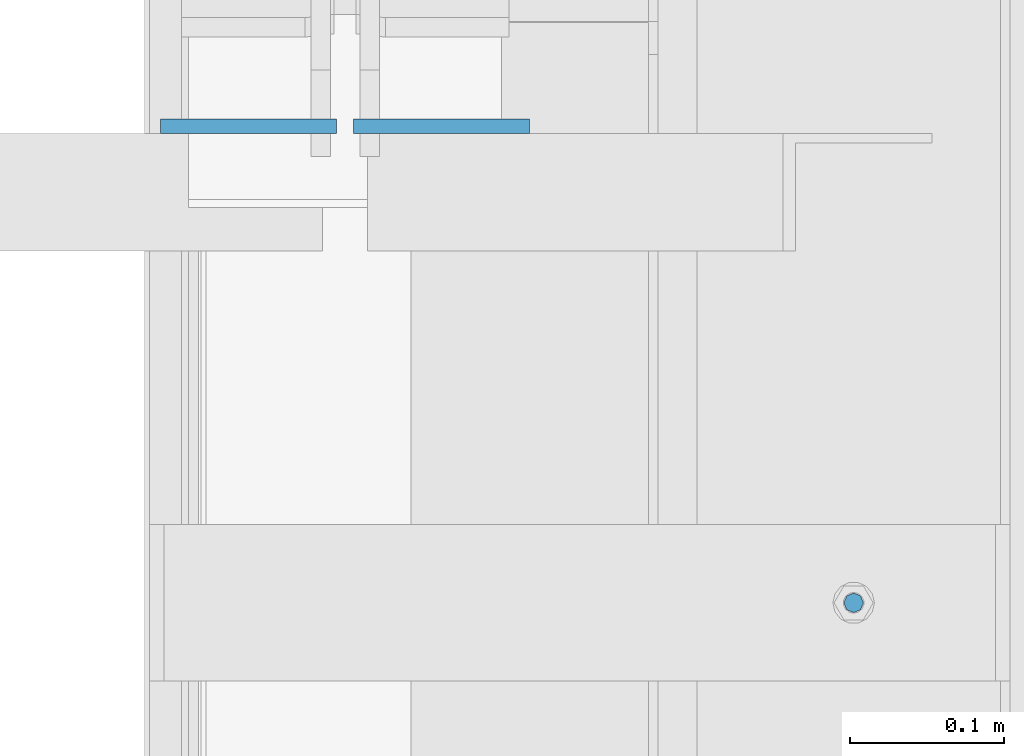
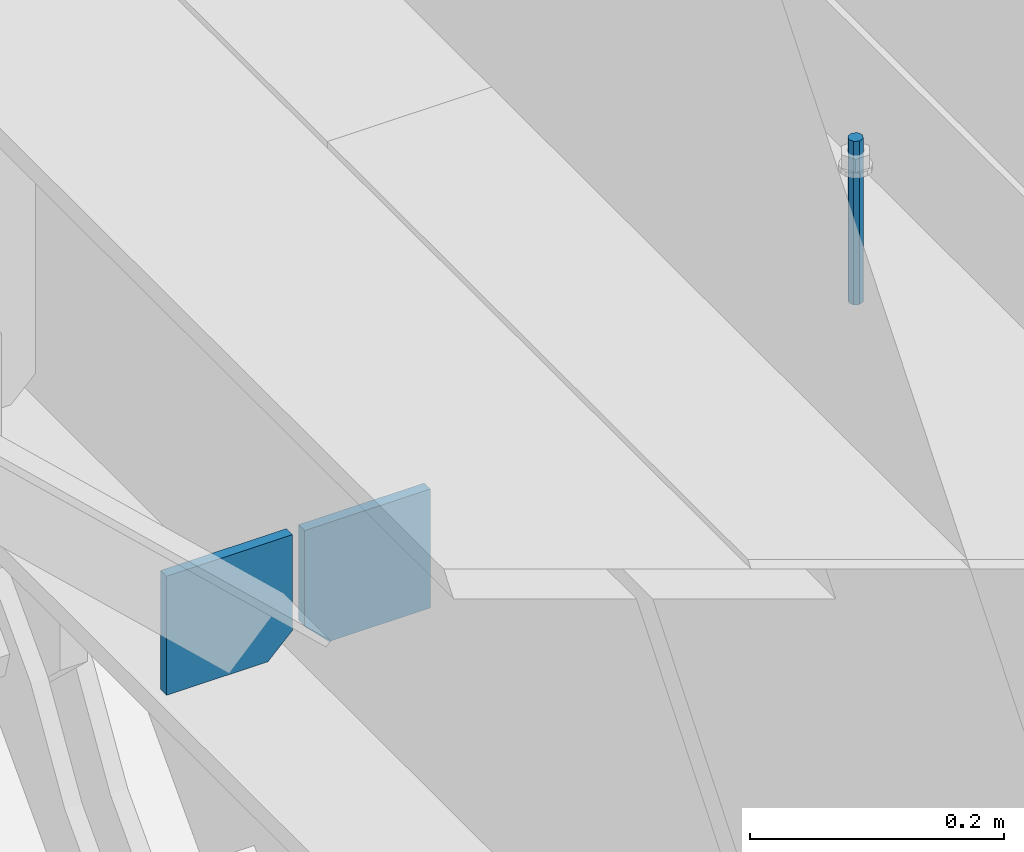
# One storey, part 411 of 1179: 3 columns, 1 element without a shape of its own.
"""IFC2X3 building model written with IfcOpenShell, lengths in millimetres."""

from ifc_helpers import new_model, si_unit, frame, origin_with_axes, place, context, subcontext, project, spatial, faceted_brep, material, type_object, element, aggregate, save


model = new_model("IFC2X3")

# Units and contexts
model_context = context("Model", 3, precision=1e-05, world=origin_with_axes())
body_context = subcontext(model_context, "Body", "Model", "MODEL_VIEW")
ifc_project = project(units=[si_unit("LENGTHUNIT", "METRE", prefix="MILLI"), si_unit("AREAUNIT", "SQUARE_METRE"), si_unit("VOLUMEUNIT", "CUBIC_METRE"), si_unit("MASSUNIT", "GRAM", prefix="KILO"), si_unit("TIMEUNIT", "SECOND"), si_unit("PLANEANGLEUNIT", "RADIAN"), si_unit("SOLIDANGLEUNIT", "STERADIAN"), si_unit("THERMODYNAMICTEMPERATUREUNIT", "DEGREE_CELSIUS"), si_unit("LUMINOUSINTENSITYUNIT", "LUMEN")], contexts=[model_context])

# Site, building, storey
site_placement = place(None, origin_with_axes())
site = spatial("IfcSite", under=ifc_project, at=site_placement, CompositionType="ELEMENT")
building_placement = place(site_placement, origin_with_axes())
building = spatial("IfcBuilding", under=site, at=building_placement, Name="Undefined", CompositionType="ELEMENT")
storey_placement = place(building_placement, origin_with_axes())
storey = spatial("IfcBuildingStorey", under=building, at=storey_placement, Name="Undefined", CompositionType="ELEMENT", Elevation=0.0)

# Assembly, columns
assembly_placement = place(storey_placement, origin_with_axes())
assembly = element("IfcElementAssembly", 1, at=assembly_placement, inside=storey, Name="BEAM", AssemblyPlace="NOTDEFINED", PredefinedType="RIGID_FRAME")
ifc_material_1 = material(Name="STEEL/A36")
column_type_1 = type_object("IfcColumnType", PredefinedType="NOTDEFINED")
column_1_placement = place(assembly_placement, frame((24245.09375, 14444.6625, 3702.05), z_axis=(1.0, 0.0, 0.0), x_axis=(0.0, 0.0, 1.0)))
column_1 = element("IfcColumn", 2, at=column_1_placement, type_object=column_type_1, material=ifc_material_1, Name="PLATE", context=body_context, shape_type="Brep", body=[
    faceted_brep([(22.2250000000004, 4.76250000000073, 57.1500000000015), (0.0, 4.76250000000073, 34.9249999999993), (0.0, -4.76250000000073, 34.9249999999993), (22.2250000000004, -4.76250000000073, 57.1500000000015), (114.300000000001, 4.76250000000073, 57.1500000000015), (114.300000000001, 4.76250000000073, -57.1500000000015), (0.0, 4.76250000000073, -57.1500000000015), (114.300000000001, -4.76250000000073, 57.1500000000015), (0.0, -4.76250000000073, -57.1500000000015), (114.300000000001, -4.76250000000073, -57.1500000000015)], [[[0, 1, 2, 3]], [[4, 5, 6, 1, 0]], [[7, 4, 0, 3]], [[8, 9, 7, 3, 2]], [[8, 6, 5, 9]], [[7, 9, 5, 4]], [[6, 8, 2, 1]]]),
])
column_2_placement = place(assembly_placement, frame((24370.50625, 14444.6625, 3702.05), z_axis=(-1.0, 0.0, 0.0), x_axis=(0.0, 0.0, 1.0)))
column_2 = element("IfcColumn", 3, at=column_2_placement, type_object=column_type_1, material=ifc_material_1, Name="PLATE", context=body_context, shape_type="Brep", body=[
    faceted_brep([(22.2250000000004, 4.76250000000073, 57.1500000000015), (0.0, 4.76250000000073, 34.9249999999993), (0.0, -4.76250000000073, 34.9249999999993), (22.2250000000004, -4.76250000000073, 57.1500000000015), (114.300000000001, 4.76250000000073, 57.1500000000015), (114.300000000001, 4.76250000000073, -57.1500000000015), (0.0, 4.76250000000073, -57.1500000000015), (114.300000000001, -4.76250000000073, 57.1500000000015), (0.0, -4.76250000000073, -57.1500000000015), (114.300000000001, -4.76250000000073, -57.1500000000015)], [[[0, 1, 2, 3]], [[4, 5, 6, 1, 0]], [[7, 4, 0, 3]], [[8, 9, 7, 3, 2]], [[8, 6, 5, 9]], [[7, 9, 5, 4]], [[6, 8, 2, 1]]]),
])
ifc_material_2 = material(Name="STEEL/A307")
column_type_2 = type_object("IfcColumnType", PredefinedType="NOTDEFINED")
column_3_placement = place(assembly_placement, frame((24638.0, 14135.1, 4108.45), z_axis=(0.0, 1.0, 0.0), x_axis=(0.0, 0.0, 1.0)))
column_3 = element("IfcColumn", 4, at=column_3_placement, type_object=column_type_2, material=ifc_material_2, Name="THREADED ROD", context=body_context, shape_type="Brep", body=[
    faceted_brep([(0.0, -6.34999999999854, 0.0), (0.0, -4.49012806053361, -4.49012806053452), (157.162499999999, -4.49012806053361, -4.49012806053361), (157.162499999999, -6.34999999999854, 0.0), (0.0, 0.0, -6.34999999999991), (157.162499999999, 0.0, -6.34999999999854), (0.0, 4.49012806053361, -4.49012806053452), (157.162499999999, 4.49012806053361, -4.49012806053361), (0.0, 6.34999999999854, 0.0), (157.162499999999, 6.34999999999854, 0.0), (0.0, 4.49012806053361, 4.49012806053452), (157.162499999999, 4.49012806053361, 4.49012806053361), (0.0, 0.0, 6.34999999999991), (157.162499999999, 0.0, 6.34999999999854), (0.0, -4.49012806053361, 4.49012806053452), (157.162499999999, -4.49012806053361, 4.49012806053361)], [[[0, 1, 2, 3]], [[1, 4, 5, 2]], [[4, 6, 7, 5]], [[6, 8, 9, 7]], [[8, 10, 11, 9]], [[10, 12, 13, 11]], [[12, 14, 15, 13]], [[14, 0, 3, 15]], [[5, 7, 9, 11, 13, 15, 3, 2]], [[14, 12, 10, 8, 6, 4, 1, 0]]]),
])
aggregate(assembly, [column_3, column_1, column_2])

save(model, "model.ifc")
